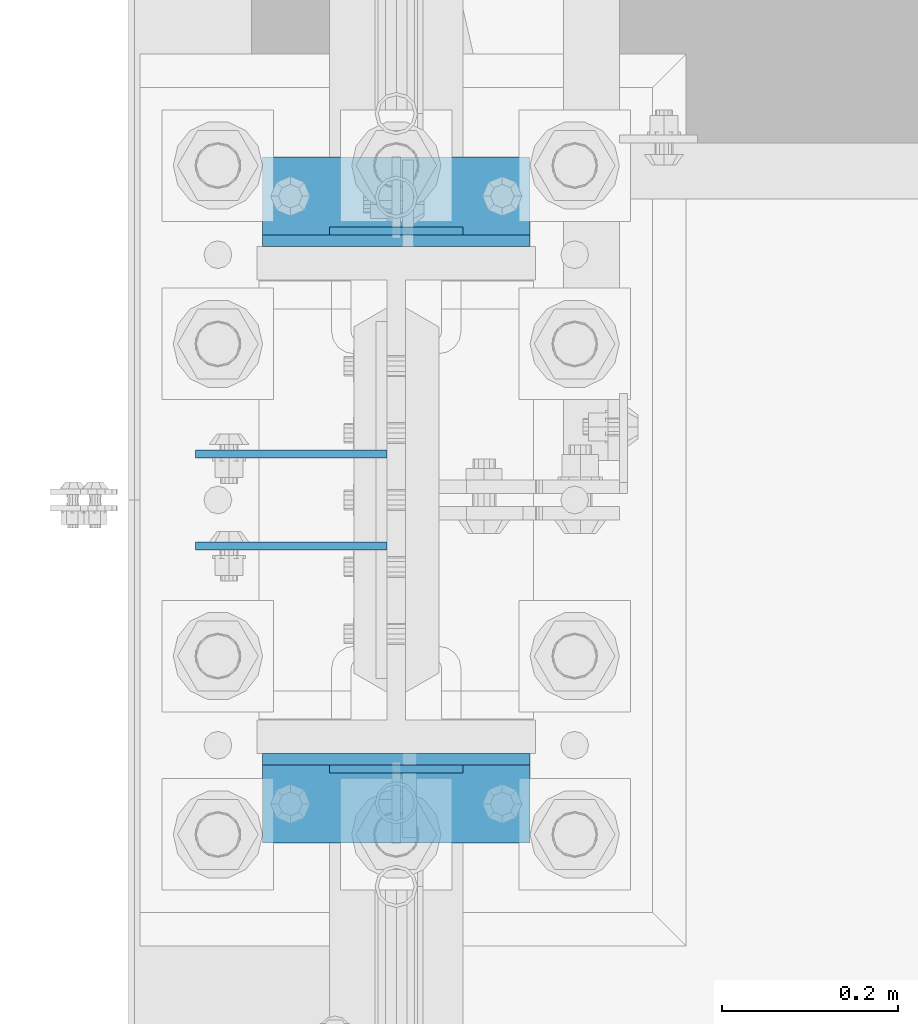
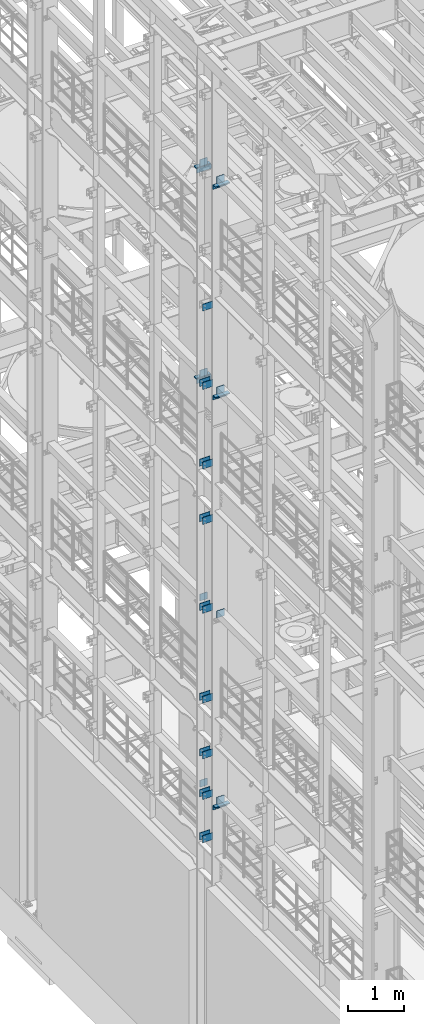
# One storey, part 1236 of 1876: 35 beams, 10 elements without a shape of their own.
"""IFC2X3 building model written with IfcOpenShell, lengths in millimetres."""

import ifcopenshell
import ifcopenshell.guid

model = None  # the IFC model being written
_history = None  # IfcOwnerHistory: only IFC2X3 demands one
_inside = {}  # id of a spatial element -> (the spatial element, [elements in it])
_under = {}  # id of a project, library or spatial element -> (it, [spatial elements below it])
_declared = {}  # id of a project -> (the project, [libraries it declares])
_typed = {}  # id of a type object -> (the type object, [elements of that type])
_made_of = {}  # id of a material, layer set ... -> (it, [elements and type objects made of it])


def new_model(schema):
    """Start an empty IFC model of exactly this schema.

    Asked for "IFC4X3", IfcOpenShell would pick the latest addendum, in which some entities
    have other attributes; the version numbers below select the first issue.
    IFC2X3 requires an IfcOwnerHistory on every rooted entity: one is made here for all.
    """
    global model, _history
    if schema == "IFC4X3":
        model = ifcopenshell.file(schema_version=(4, 3, 0, 0))
    else:
        model = ifcopenshell.file(schema=schema)
    _inside.clear()
    _under.clear()
    _declared.clear()
    _typed.clear()
    _made_of.clear()
    _history = None
    if model.schema == "IFC2X3":
        org = make("IfcOrganization", Name="unknown")
        user = make(
            "IfcPersonAndOrganization",
            ThePerson=make("IfcPerson", FamilyName="unknown"),
            TheOrganization=org,
        )
        app = make(
            "IfcApplication",
            ApplicationDeveloper=org,
            Version="unknown",
            ApplicationFullName="unknown",
            ApplicationIdentifier="unknown",
        )
        _history = make(
            "IfcOwnerHistory",
            OwningUser=user,
            OwningApplication=app,
            ChangeAction="ADDED",
            CreationDate=0,
        )
    return model


def make(cls, **values):
    """One entity of the class cls with the attributes given. An attribute that is None is left unset."""
    return model.create_entity(
        cls, **{name: value for name, value in values.items() if value is not None}
    )


def rooted(cls, **values):
    """An entity with a GlobalId (a new one), such as an element, a storey or a relation."""
    return make(cls, GlobalId=ifcopenshell.guid.new(), OwnerHistory=_history, **values)


def si_unit(unit_type, name, prefix=None):
    """IfcSIUnit, for example si_unit("LENGTHUNIT", "METRE", prefix="MILLI")."""
    return make("IfcSIUnit", UnitType=unit_type, Prefix=prefix, Name=name)


def assignment(units):
    """IfcUnitAssignment: the units of a project."""
    return None if units is None else make("IfcUnitAssignment", Units=units)


def point(xyz):
    """IfcCartesianPoint."""
    return None if xyz is None else make("IfcCartesianPoint", Coordinates=xyz)


def direction(xyz):
    """IfcDirection."""
    return None if xyz is None else make("IfcDirection", DirectionRatios=xyz)


def frame(location, z_axis=None, x_axis=None):
    """IfcAxis2Placement3D, a coordinate frame: its origin and axes. An axis left out is left unset."""
    return make(
        "IfcAxis2Placement3D",
        Location=point(location),
        Axis=direction(z_axis),
        RefDirection=direction(x_axis),
    )


def origin_with_axes():
    """The frame at (0, 0, 0) with the z axis (0, 0, 1) and the x axis (1, 0, 0) written out."""
    return frame((0.0, 0.0, 0.0), z_axis=(0.0, 0.0, 1.0), x_axis=(1.0, 0.0, 0.0))


def place(relative_to, where):
    """IfcLocalPlacement: puts the frame where relative to a parent placement (None: the world)."""
    return make(
        "IfcLocalPlacement", PlacementRelTo=relative_to, RelativePlacement=where
    )


def context(
    kind, dimensions, precision=None, world=None, true_north=None, identifier=None
):
    """IfcGeometricRepresentationContext, for example the 3D "Model" context."""
    return make(
        "IfcGeometricRepresentationContext",
        ContextIdentifier=identifier,
        ContextType=kind,
        CoordinateSpaceDimension=dimensions,
        Precision=precision,
        WorldCoordinateSystem=world,
        TrueNorth=true_north,
    )


def subcontext(parent, identifier, kind, view, scale=None):
    """IfcGeometricRepresentationSubContext, for example "Body" below "Model"."""
    return make(
        "IfcGeometricRepresentationSubContext",
        ContextIdentifier=identifier,
        ContextType=kind,
        ParentContext=parent,
        TargetScale=scale,
        TargetView=view,
    )


def project(units=None, contexts=None):
    """IfcProject with its units and contexts."""
    return rooted(
        "IfcProject",
        Name="project",
        RepresentationContexts=contexts,
        UnitsInContext=assignment(units),
    )


def spatial(cls, under=None, at=None, **own):
    """A site, building, storey or space (cls), placed at a placement, below another one or the project."""
    s = rooted(cls, ObjectPlacement=at, **own)
    if under is not None:
        _under.setdefault(under.id(), (under, []))[1].append(s)
    return s


def faces_of(points, faces, orient=None, outer=None):
    """IfcFace entities. A face is a list of loops; a loop is a list of indices into points, from 0.

    orient and outer hold one flag for each loop. By default every Orientation is true, the
    first loop of a face is its IfcFaceOuterBound and the others are IfcFaceBound.
    """
    made = []
    for i, loops in enumerate(faces):
        bounds = []
        for j, loop in enumerate(loops):
            is_outer = j == 0 if outer is None else outer[i][j]
            bounds.append(
                make(
                    "IfcFaceOuterBound" if is_outer else "IfcFaceBound",
                    Bound=make("IfcPolyLoop", Polygon=[points[k] for k in loop]),
                    Orientation=True if orient is None else orient[i][j],
                )
            )
        made.append(make("IfcFace", Bounds=bounds))
    return made


def faceted_brep(points, faces, orient=None, outer=None, voids=None):
    """IfcFacetedBrep: a solid bounded by flat faces; with voids (closed shells), ...WithVoids."""
    shared = [point(p) for p in points]
    hull = make("IfcClosedShell", CfsFaces=faces_of(shared, faces, orient, outer))
    if voids is None:
        return make("IfcFacetedBrep", Outer=hull)
    return make(
        "IfcFacetedBrepWithVoids",
        Outer=hull,
        Voids=[
            make(cls, CfsFaces=faces_of(shared, fs, o, b)) for cls, fs, o, b in voids
        ],
    )


def shape(context_of_items, identifier, shape_type, items):
    """IfcShapeRepresentation: the items that make up one representation, for example the "Body"."""
    return make(
        "IfcShapeRepresentation",
        ContextOfItems=context_of_items,
        RepresentationIdentifier=identifier,
        RepresentationType=shape_type,
        Items=items,
    )


def material(Name=None, Category=None):
    """IfcMaterial."""
    return make("IfcMaterial", Name=Name, Category=Category)


def made_of(thing, what):
    """Note that an element or type object is made of a material, layer set ...; save() writes the relation."""
    if what is not None:
        _made_of.setdefault(what.id(), (what, []))[1].append(thing)
    return thing


def type_object(cls, material=None, **own):
    """A type object (cls), such as IfcWallType, which elements share."""
    return made_of(rooted(cls, **own), material)


def element(
    cls,
    number,
    at=None,
    inside=None,
    cuts=None,
    type_object=None,
    material=None,
    context=None,
    identifier="Body",
    shape_type=None,
    held_by="IfcProductDefinitionShape",
    body=None,
    shapes=None,
    **own,
):
    """One element of the class cls, such as IfcWall. Its Tag is "e" and its number.

    at: its placement. inside: the storey or other place that contains it. cuts: it is an
    opening in that element (IfcRelVoidsElement). A single representation is given by context,
    identifier, shape_type and body (its items); several are given by shapes. held_by: the class
    of the entity that holds the representations. save() writes the other relations.
    """
    e = rooted(cls, Tag="e%d" % number, ObjectPlacement=at, **own)
    if body is not None:
        shapes = [shape(context, identifier, shape_type, body)]
    if shapes is not None:
        e.Representation = make(held_by, Representations=shapes)
    if inside is not None:
        _inside.setdefault(inside.id(), (inside, []))[1].append(e)
    if cuts is not None:
        rooted(
            "IfcRelVoidsElement", RelatingBuildingElement=cuts, RelatedOpeningElement=e
        )
    if type_object is not None:
        _typed.setdefault(type_object.id(), (type_object, []))[1].append(e)
    return made_of(e, material)


def aggregate(whole, parts):
    """IfcRelAggregates: a whole, such as a stair, and the parts it consists of."""
    return rooted("IfcRelAggregates", RelatingObject=whole, RelatedObjects=parts)


def save(model, path):
    """Write the relations noted so far, then the file.

    IfcRelAggregates (storeys below a building ...), IfcRelContainedInSpatialStructure (elements
    in a storey), IfcRelDefinesByType, IfcRelAssociatesMaterial and IfcRelDeclares: one each for
    every whole, place, type object, material and project.
    """
    for whole, parts in _under.values():
        aggregate(whole, parts)
    for where, things in _inside.values():
        rooted(
            "IfcRelContainedInSpatialStructure",
            RelatedElements=things,
            RelatingStructure=where,
        )
    for kind, things in _typed.values():
        rooted("IfcRelDefinesByType", RelatedObjects=things, RelatingType=kind)
    for what, things in _made_of.values():
        rooted("IfcRelAssociatesMaterial", RelatedObjects=things, RelatingMaterial=what)
    for by, libraries in _declared.values():
        rooted("IfcRelDeclares", RelatingContext=by, RelatedDefinitions=libraries)
    model.write(path)


model = new_model("IFC2X3")

# Units and contexts
model_context = context("Model", 3, precision=1e-05, world=origin_with_axes())
body_context = subcontext(model_context, "Body", "Model", "MODEL_VIEW")
ifc_project = project(units=[si_unit("LENGTHUNIT", "METRE", prefix="MILLI"), si_unit("AREAUNIT", "SQUARE_METRE"), si_unit("VOLUMEUNIT", "CUBIC_METRE"), si_unit("MASSUNIT", "GRAM", prefix="KILO"), si_unit("TIMEUNIT", "SECOND"), si_unit("PLANEANGLEUNIT", "RADIAN"), si_unit("SOLIDANGLEUNIT", "STERADIAN"), si_unit("THERMODYNAMICTEMPERATUREUNIT", "DEGREE_CELSIUS"), si_unit("LUMINOUSINTENSITYUNIT", "LUMEN")], contexts=[model_context])

# Site, building, storey
site_placement = place(None, origin_with_axes())
site = spatial("IfcSite", under=ifc_project, at=site_placement, CompositionType="ELEMENT")
building_placement = place(site_placement, origin_with_axes())
building = spatial("IfcBuilding", under=site, at=building_placement, Name="Undefined", CompositionType="ELEMENT")
storey_placement = place(building_placement, origin_with_axes())
storey = spatial("IfcBuildingStorey", under=building, at=storey_placement, Name="Undefined", CompositionType="ELEMENT", Elevation=0.0)

# Assembly, beams
assembly_1_placement = place(storey_placement, origin_with_axes())
assembly_1 = element("IfcElementAssembly", 1, at=assembly_1_placement, inside=storey, Name="COLUMN", AssemblyPlace="NOTDEFINED", PredefinedType="RIGID_FRAME")
ifc_material = material(Name="STEEL/A36")
beam_type_1 = type_object("IfcBeamType", PredefinedType="NOTDEFINED")
beam_1_placement = place(assembly_1_placement, frame((-10.31875, 1471.61250152589, 17056.1), z_axis=(0.0, 0.0, -1.0), x_axis=(-1.0, 0.0, 0.0)))
beam_1 = element("IfcBeam", 2, at=beam_1_placement, type_object=beam_type_1, material=ifc_material, Name="PLATE", context=body_context, shape_type="Brep", body=[
    faceted_brep([(0.0, 4.76249999999982, -76.1999999999998), (3.63797880709171e-12, 4.76249999999982, 76.1999969482422), (218.28125, 4.76250000000005, 76.2000000000007), (218.28125, 4.76250000000005, -76.2000000000007), (3.63797880709171e-12, -4.76249999999982, 76.1999969482422), (218.28125, -4.76250000000005, 76.2000000000007), (0.0, -4.76249999999982, -76.1999999999998), (218.28125, -4.76250000000005, -76.2000000000007)], [[[0, 1, 2, 3]], [[1, 4, 5, 2]], [[4, 6, 7, 5]], [[6, 0, 3, 7]], [[5, 7, 3, 2]], [[6, 4, 1, 0]]]),
])
beam_2_placement = place(assembly_1_placement, frame((-10.31875, 1576.38750152589, 15335.25), z_axis=(0.0, 0.0, -1.0), x_axis=(-1.0, 0.0, 0.0)))
beam_2 = element("IfcBeam", 3, at=beam_2_placement, type_object=beam_type_1, material=ifc_material, Name="PLATE", context=body_context, shape_type="Brep", body=[
    faceted_brep([(0.0, 4.76249999999982, -76.1999999999998), (3.63797880709171e-12, 4.76249999999982, 76.1999969482422), (218.28125, 4.76250000000005, 76.2000000000007), (218.28125, 4.76250000000005, -76.2000000000007), (3.63797880709171e-12, -4.76249999999982, 76.1999969482422), (218.28125, -4.76250000000005, 76.2000000000007), (0.0, -4.76249999999982, -76.1999999999998), (218.28125, -4.76250000000005, -76.2000000000007)], [[[0, 1, 2, 3]], [[1, 4, 5, 2]], [[4, 6, 7, 5]], [[6, 0, 3, 7]], [[5, 7, 3, 2]], [[6, 4, 1, 0]]]),
])
beam_3_placement = place(assembly_1_placement, frame((-10.31875, 1471.61250152589, 15335.25), z_axis=(0.0, 0.0, -1.0), x_axis=(-1.0, 0.0, 0.0)))
beam_3 = element("IfcBeam", 4, at=beam_3_placement, type_object=beam_type_1, material=ifc_material, Name="PLATE", context=body_context, shape_type="Brep", body=[
    faceted_brep([(0.0, 4.76249999999982, -76.1999999999998), (3.63797880709171e-12, 4.76249999999982, 76.1999969482422), (218.28125, 4.76250000000005, 76.2000000000007), (218.28125, 4.76250000000005, -76.2000000000007), (3.63797880709171e-12, -4.76249999999982, 76.1999969482422), (218.28125, -4.76250000000005, 76.2000000000007), (0.0, -4.76249999999982, -76.1999999999998), (218.28125, -4.76250000000005, -76.2000000000007)], [[[0, 1, 2, 3]], [[1, 4, 5, 2]], [[4, 6, 7, 5]], [[6, 0, 3, 7]], [[5, 7, 3, 2]], [[6, 4, 1, 0]]]),
])

assembly_2_placement = place(storey_placement, origin_with_axes())
assembly_2 = element("IfcElementAssembly", 5, at=assembly_2_placement, inside=storey, Name="COLUMN", AssemblyPlace="NOTDEFINED", PredefinedType="RIGID_FRAME")
beam_4_placement = place(assembly_2_placement, frame((-10.31875, 1576.38750152589, 13589.0), z_axis=(0.0, 0.0, -1.0), x_axis=(-1.0, 0.0, 0.0)))
beam_4 = element("IfcBeam", 6, at=beam_4_placement, type_object=beam_type_1, material=ifc_material, Name="PLATE", context=body_context, shape_type="Brep", body=[
    faceted_brep([(0.0, 4.76249999999982, -76.1999999999998), (3.63797880709171e-12, 4.76249999999982, 76.1999969482422), (218.28125, 4.76250000000005, 76.2000000000007), (218.28125, 4.76250000000005, -76.2000000000007), (3.63797880709171e-12, -4.76249999999982, 76.1999969482422), (218.28125, -4.76250000000005, 76.2000000000007), (0.0, -4.76249999999982, -76.1999999999998), (218.28125, -4.76250000000005, -76.2000000000007)], [[[0, 1, 2, 3]], [[1, 4, 5, 2]], [[4, 6, 7, 5]], [[6, 0, 3, 7]], [[5, 7, 3, 2]], [[6, 4, 1, 0]]]),
])
beam_5_placement = place(assembly_2_placement, frame((-10.31875, 1471.61250152589, 13589.0), z_axis=(0.0, 0.0, -1.0), x_axis=(-1.0, 0.0, 0.0)))
beam_5 = element("IfcBeam", 7, at=beam_5_placement, type_object=beam_type_1, material=ifc_material, Name="PLATE", context=body_context, shape_type="Brep", body=[
    faceted_brep([(0.0, 4.76249999999982, -76.1999999999998), (3.63797880709171e-12, 4.76249999999982, 76.1999969482422), (218.28125, 4.76250000000005, 76.2000000000007), (218.28125, 4.76250000000005, -76.2000000000007), (3.63797880709171e-12, -4.76249999999982, 76.1999969482422), (218.28125, -4.76250000000005, 76.2000000000007), (0.0, -4.76249999999982, -76.1999999999998), (218.28125, -4.76250000000005, -76.2000000000007)], [[[0, 1, 2, 3]], [[1, 4, 5, 2]], [[4, 6, 7, 5]], [[6, 0, 3, 7]], [[5, 7, 3, 2]], [[6, 4, 1, 0]]]),
])
beam_6_placement = place(assembly_2_placement, frame((-10.31875, 1576.38750152589, 12369.8), z_axis=(0.0, 0.0, -1.0), x_axis=(-1.0, 0.0, 0.0)))
beam_6 = element("IfcBeam", 8, at=beam_6_placement, type_object=beam_type_1, material=ifc_material, Name="PLATE", context=body_context, shape_type="Brep", body=[
    faceted_brep([(0.0, 4.76249999999982, -76.1999999999998), (3.63797880709171e-12, 4.76249999999982, 76.1999969482422), (218.28125, 4.76250000000005, 76.2000000000007), (218.28125, 4.76250000000005, -76.2000000000007), (3.63797880709171e-12, -4.76249999999982, 76.1999969482422), (218.28125, -4.76250000000005, 76.2000000000007), (0.0, -4.76249999999982, -76.1999999999998), (218.28125, -4.76250000000005, -76.2000000000007)], [[[0, 1, 2, 3]], [[1, 4, 5, 2]], [[4, 6, 7, 5]], [[6, 0, 3, 7]], [[5, 7, 3, 2]], [[6, 4, 1, 0]]]),
])
beam_7_placement = place(assembly_2_placement, frame((-10.31875, 1471.61250152589, 12369.8), z_axis=(0.0, 0.0, -1.0), x_axis=(-1.0, 0.0, 0.0)))
beam_7 = element("IfcBeam", 9, at=beam_7_placement, type_object=beam_type_1, material=ifc_material, Name="PLATE", context=body_context, shape_type="Brep", body=[
    faceted_brep([(0.0, 4.76249999999982, -76.1999999999998), (3.63797880709171e-12, 4.76249999999982, 76.1999969482422), (218.28125, 4.76250000000005, 76.2000000000007), (218.28125, 4.76250000000005, -76.2000000000007), (3.63797880709171e-12, -4.76249999999982, 76.1999969482422), (218.28125, -4.76250000000005, 76.2000000000007), (0.0, -4.76249999999982, -76.1999999999998), (218.28125, -4.76250000000005, -76.2000000000007)], [[[0, 1, 2, 3]], [[1, 4, 5, 2]], [[4, 6, 7, 5]], [[6, 0, 3, 7]], [[5, 7, 3, 2]], [[6, 4, 1, 0]]]),
])
beam_8_placement = place(assembly_2_placement, frame((-10.31875, 1576.38750152589, 10420.35), z_axis=(0.0, 0.0, -1.0), x_axis=(-1.0, 0.0, 0.0)))
beam_8 = element("IfcBeam", 10, at=beam_8_placement, type_object=beam_type_1, material=ifc_material, Name="PLATE", context=body_context, shape_type="Brep", body=[
    faceted_brep([(0.0, 4.76249999999982, -76.1999999999998), (3.63797880709171e-12, 4.76249999999982, 76.1999969482422), (218.28125, 4.76250000000005, 76.2000000000007), (218.28125, 4.76250000000005, -76.2000000000007), (3.63797880709171e-12, -4.76249999999982, 76.1999969482422), (218.28125, -4.76250000000005, 76.2000000000007), (0.0, -4.76249999999982, -76.1999999999998), (218.28125, -4.76250000000005, -76.2000000000007)], [[[0, 1, 2, 3]], [[1, 4, 5, 2]], [[4, 6, 7, 5]], [[6, 0, 3, 7]], [[5, 7, 3, 2]], [[6, 4, 1, 0]]]),
])
beam_9_placement = place(assembly_2_placement, frame((-10.31875, 1471.61250152589, 10420.35), z_axis=(0.0, 0.0, -1.0), x_axis=(-1.0, 0.0, 0.0)))
beam_9 = element("IfcBeam", 11, at=beam_9_placement, type_object=beam_type_1, material=ifc_material, Name="PLATE", context=body_context, shape_type="Brep", body=[
    faceted_brep([(0.0, 4.76249999999982, -76.1999999999998), (3.63797880709171e-12, 4.76249999999982, 76.1999969482422), (218.28125, 4.76250000000005, 76.2000000000007), (218.28125, 4.76250000000005, -76.2000000000007), (3.63797880709171e-12, -4.76249999999982, 76.1999969482422), (218.28125, -4.76250000000005, 76.2000000000007), (0.0, -4.76249999999982, -76.1999999999998), (218.28125, -4.76250000000005, -76.2000000000007)], [[[0, 1, 2, 3]], [[1, 4, 5, 2]], [[4, 6, 7, 5]], [[6, 0, 3, 7]], [[5, 7, 3, 2]], [[6, 4, 1, 0]]]),
])
beam_10_placement = place(assembly_2_placement, frame((-10.31875, 1576.38750152589, 8445.5), z_axis=(0.0, 0.0, -1.0), x_axis=(-1.0, 0.0, 0.0)))
beam_10 = element("IfcBeam", 12, at=beam_10_placement, type_object=beam_type_1, material=ifc_material, Name="PLATE", context=body_context, shape_type="Brep", body=[
    faceted_brep([(0.0, 4.76249999999982, -76.1999999999998), (3.63797880709171e-12, 4.76249999999982, 76.1999969482422), (218.28125, 4.76250000000005, 76.2000000000007), (218.28125, 4.76250000000005, -76.2000000000007), (3.63797880709171e-12, -4.76249999999982, 76.1999969482422), (218.28125, -4.76250000000005, 76.2000000000007), (0.0, -4.76249999999982, -76.1999999999998), (218.28125, -4.76250000000005, -76.2000000000007)], [[[0, 1, 2, 3]], [[1, 4, 5, 2]], [[4, 6, 7, 5]], [[6, 0, 3, 7]], [[5, 7, 3, 2]], [[6, 4, 1, 0]]]),
])
beam_11_placement = place(assembly_2_placement, frame((-10.31875, 1471.61250152589, 8445.5), z_axis=(0.0, 0.0, -1.0), x_axis=(-1.0, 0.0, 0.0)))
beam_11 = element("IfcBeam", 13, at=beam_11_placement, type_object=beam_type_1, material=ifc_material, Name="PLATE", context=body_context, shape_type="Brep", body=[
    faceted_brep([(0.0, 4.76249999999982, -76.1999999999998), (3.63797880709171e-12, 4.76249999999982, 76.1999969482422), (218.28125, 4.76250000000005, 76.2000000000007), (218.28125, 4.76250000000005, -76.2000000000007), (3.63797880709171e-12, -4.76249999999982, 76.1999969482422), (218.28125, -4.76250000000005, 76.2000000000007), (0.0, -4.76249999999982, -76.1999999999998), (218.28125, -4.76250000000005, -76.2000000000007)], [[[0, 1, 2, 3]], [[1, 4, 5, 2]], [[4, 6, 7, 5]], [[6, 0, 3, 7]], [[5, 7, 3, 2]], [[6, 4, 1, 0]]]),
])
beam_12_placement = place(assembly_2_placement, frame((-10.31875, 1576.38750152589, 7226.3), z_axis=(0.0, 0.0, -1.0), x_axis=(-1.0, 0.0, 0.0)))
beam_12 = element("IfcBeam", 14, at=beam_12_placement, type_object=beam_type_1, material=ifc_material, Name="PLATE", context=body_context, shape_type="Brep", body=[
    faceted_brep([(0.0, 4.76249999999982, -76.1999999999998), (3.63797880709171e-12, 4.76249999999982, 76.1999969482422), (218.28125, 4.76250000000005, 76.2000000000007), (218.28125, 4.76250000000005, -76.2000000000007), (3.63797880709171e-12, -4.76249999999982, 76.1999969482422), (218.28125, -4.76250000000005, 76.2000000000007), (0.0, -4.76249999999982, -76.1999999999998), (218.28125, -4.76250000000005, -76.2000000000007)], [[[0, 1, 2, 3]], [[1, 4, 5, 2]], [[4, 6, 7, 5]], [[6, 0, 3, 7]], [[5, 7, 3, 2]], [[6, 4, 1, 0]]]),
])
beam_13_placement = place(assembly_2_placement, frame((-10.31875, 1471.61250152589, 7226.3), z_axis=(0.0, 0.0, -1.0), x_axis=(-1.0, 0.0, 0.0)))
beam_13 = element("IfcBeam", 15, at=beam_13_placement, type_object=beam_type_1, material=ifc_material, Name="PLATE", context=body_context, shape_type="Brep", body=[
    faceted_brep([(0.0, 4.76249999999982, -76.1999999999998), (3.63797880709171e-12, 4.76249999999982, 76.1999969482422), (218.28125, 4.76250000000005, 76.2000000000007), (218.28125, 4.76250000000005, -76.2000000000007), (3.63797880709171e-12, -4.76249999999982, 76.1999969482422), (218.28125, -4.76250000000005, 76.2000000000007), (0.0, -4.76249999999982, -76.1999999999998), (218.28125, -4.76250000000005, -76.2000000000007)], [[[0, 1, 2, 3]], [[1, 4, 5, 2]], [[4, 6, 7, 5]], [[6, 0, 3, 7]], [[5, 7, 3, 2]], [[6, 4, 1, 0]]]),
])
beam_14_placement = place(assembly_2_placement, frame((-10.31875, 1576.38750152589, 5384.8), z_axis=(0.0, 0.0, -1.0), x_axis=(-1.0, 0.0, 0.0)))
beam_14 = element("IfcBeam", 16, at=beam_14_placement, type_object=beam_type_1, material=ifc_material, Name="PLATE", context=body_context, shape_type="Brep", body=[
    faceted_brep([(0.0, 4.76249999999982, -76.1999999999998), (3.63797880709171e-12, 4.76249999999982, 76.1999969482422), (218.28125, 4.76250000000005, 76.2000000000007), (218.28125, 4.76250000000005, -76.2000000000007), (3.63797880709171e-12, -4.76249999999982, 76.1999969482422), (218.28125, -4.76250000000005, 76.2000000000007), (0.0, -4.76249999999982, -76.1999999999998), (218.28125, -4.76250000000005, -76.2000000000007)], [[[0, 1, 2, 3]], [[1, 4, 5, 2]], [[4, 6, 7, 5]], [[6, 0, 3, 7]], [[5, 7, 3, 2]], [[6, 4, 1, 0]]]),
])
beam_15_placement = place(assembly_2_placement, frame((-10.31875, 1471.61250152589, 5384.8), z_axis=(0.0, 0.0, -1.0), x_axis=(-1.0, 0.0, 0.0)))
beam_15 = element("IfcBeam", 17, at=beam_15_placement, type_object=beam_type_1, material=ifc_material, Name="PLATE", context=body_context, shape_type="Brep", body=[
    faceted_brep([(0.0, 4.76249999999982, -76.1999999999998), (3.63797880709171e-12, 4.76249999999982, 76.1999969482422), (218.28125, 4.76250000000005, 76.2000000000007), (218.28125, 4.76250000000005, -76.2000000000007), (3.63797880709171e-12, -4.76249999999982, 76.1999969482422), (218.28125, -4.76250000000005, 76.2000000000007), (0.0, -4.76249999999982, -76.1999999999998), (218.28125, -4.76250000000005, -76.2000000000007)], [[[0, 1, 2, 3]], [[1, 4, 5, 2]], [[4, 6, 7, 5]], [[6, 0, 3, 7]], [[5, 7, 3, 2]], [[6, 4, 1, 0]]]),
])
beam_16_placement = place(assembly_2_placement, frame((-10.31875, 1576.38750152589, 6330.95), z_axis=(0.0, 0.0, -1.0), x_axis=(-1.0, 0.0, 0.0)))
beam_16 = element("IfcBeam", 18, at=beam_16_placement, type_object=beam_type_1, material=ifc_material, Name="PLATE", context=body_context, shape_type="Brep", body=[
    faceted_brep([(0.0, 4.76249999999982, -76.1999999999998), (3.63797880709171e-12, 4.76249999999982, 76.1999969482422), (218.28125, 4.76250000000005, 76.2000000000007), (218.28125, 4.76250000000005, -76.2000000000007), (3.63797880709171e-12, -4.76249999999982, 76.1999969482422), (218.28125, -4.76250000000005, 76.2000000000007), (0.0, -4.76249999999982, -76.1999999999998), (218.28125, -4.76250000000005, -76.2000000000007)], [[[0, 1, 2, 3]], [[1, 4, 5, 2]], [[4, 6, 7, 5]], [[6, 0, 3, 7]], [[5, 7, 3, 2]], [[6, 4, 1, 0]]]),
])
beam_17_placement = place(assembly_2_placement, frame((-10.31875, 1471.61250152589, 6330.95), z_axis=(0.0, 0.0, -1.0), x_axis=(-1.0, 0.0, 0.0)))
beam_17 = element("IfcBeam", 19, at=beam_17_placement, type_object=beam_type_1, material=ifc_material, Name="PLATE", context=body_context, shape_type="Brep", body=[
    faceted_brep([(0.0, 4.76249999999982, -76.1999999999998), (3.63797880709171e-12, 4.76249999999982, 76.1999969482422), (218.28125, 4.76250000000005, 76.2000000000007), (218.28125, 4.76250000000005, -76.2000000000007), (3.63797880709171e-12, -4.76249999999982, 76.1999969482422), (218.28125, -4.76250000000005, 76.2000000000007), (0.0, -4.76249999999982, -76.1999999999998), (218.28125, -4.76250000000005, -76.2000000000007)], [[[0, 1, 2, 3]], [[1, 4, 5, 2]], [[4, 6, 7, 5]], [[6, 0, 3, 7]], [[5, 7, 3, 2]], [[6, 4, 1, 0]]]),
])

# Assembly, beam
assembly_3_placement = place(storey_placement, origin_with_axes())
assembly_3 = element("IfcElementAssembly", 20, at=assembly_3_placement, inside=storey, Name="BEAM", AssemblyPlace="NOTDEFINED", PredefinedType="RIGID_FRAME")
beam_18_placement = place(assembly_3_placement, frame((76.1999999999998, 1830.3875, 19958.05), z_axis=(0.0, 0.0, 1.0), x_axis=(-1.0, 0.0, 0.0)))
beam_18 = element("IfcBeam", 21, at=beam_18_placement, type_object=beam_type_1, material=ifc_material, Name="PLATE", context=body_context, shape_type="Brep", body=[
    faceted_brep([(0.0, 4.76249999999982, -76.1999999999998), (3.63797880709171e-12, 4.76249999999982, 76.1999969482422), (152.399993896484, 4.76250000000073, 76.1999969482422), (152.4, 4.76249999999982, -76.1999999999998), (3.63797880709171e-12, -4.76249999999982, 76.1999969482422), (152.399993896484, -4.76250000000073, 76.1999969482422), (0.0, -4.76249999999982, -76.1999999999998), (152.4, -4.76249999999982, -76.1999999999998)], [[[0, 1, 2, 3]], [[4, 5, 2, 1]], [[4, 6, 7, 5]], [[6, 0, 3, 7]], [[5, 7, 3, 2]], [[6, 4, 1, 0]]]),
])

assembly_4_placement = place(storey_placement, origin_with_axes())
assembly_4 = element("IfcElementAssembly", 22, at=assembly_4_placement, inside=storey, Name="BEAM", AssemblyPlace="NOTDEFINED", PredefinedType="RIGID_FRAME")
beam_19_placement = place(assembly_4_placement, frame((76.1999999999998, 1217.6125, 19958.05), z_axis=(0.0, 0.0, -1.0), x_axis=(-1.0, 0.0, 0.0)))
beam_19 = element("IfcBeam", 23, at=beam_19_placement, type_object=beam_type_1, material=ifc_material, Name="PLATE", context=body_context, shape_type="Brep", body=[
    faceted_brep([(0.0, 4.76249999999982, -76.1999999999998), (3.63797880709171e-12, 4.76249999999982, 76.1999969482422), (152.399993896484, 4.76250000000073, 76.1999969482422), (152.4, 4.76249999999982, -76.1999999999998), (3.63797880709171e-12, -4.76249999999982, 76.1999969482422), (152.399993896484, -4.76250000000073, 76.1999969482422), (0.0, -4.76249999999982, -76.1999999999998), (152.4, -4.76249999999982, -76.1999999999998)], [[[0, 1, 2, 3]], [[4, 5, 2, 1]], [[4, 6, 7, 5]], [[6, 0, 3, 7]], [[5, 7, 3, 2]], [[6, 4, 1, 0]]]),
])

assembly_5_placement = place(storey_placement, origin_with_axes())
assembly_5 = element("IfcElementAssembly", 24, at=assembly_5_placement, inside=storey, Name="BEAM", AssemblyPlace="NOTDEFINED", PredefinedType="RIGID_FRAME")
beam_20_placement = place(assembly_5_placement, frame((76.1999999999998, 1830.3875, 15335.25), z_axis=(0.0, 0.0, 1.0), x_axis=(-1.0, 0.0, 0.0)))
beam_20 = element("IfcBeam", 25, at=beam_20_placement, type_object=beam_type_1, material=ifc_material, Name="PLATE", context=body_context, shape_type="Brep", body=[
    faceted_brep([(0.0, 4.76249999999982, -76.1999999999998), (3.63797880709171e-12, 4.76249999999982, 76.1999969482422), (152.399993896484, 4.76250000000073, 76.1999969482422), (152.4, 4.76249999999982, -76.1999999999998), (3.63797880709171e-12, -4.76249999999982, 76.1999969482422), (152.399993896484, -4.76250000000073, 76.1999969482422), (0.0, -4.76249999999982, -76.1999999999998), (152.4, -4.76249999999982, -76.1999999999998)], [[[0, 1, 2, 3]], [[4, 5, 2, 1]], [[4, 6, 7, 5]], [[6, 0, 3, 7]], [[5, 7, 3, 2]], [[6, 4, 1, 0]]]),
])

assembly_6_placement = place(storey_placement, origin_with_axes())
assembly_6 = element("IfcElementAssembly", 26, at=assembly_6_placement, inside=storey, Name="BEAM", AssemblyPlace="NOTDEFINED", PredefinedType="RIGID_FRAME")
beam_21_placement = place(assembly_6_placement, frame((76.1999999999998, 1217.6125, 15335.25), z_axis=(0.0, 0.0, -1.0), x_axis=(-1.0, 0.0, 0.0)))
beam_21 = element("IfcBeam", 27, at=beam_21_placement, type_object=beam_type_1, material=ifc_material, Name="PLATE", context=body_context, shape_type="Brep", body=[
    faceted_brep([(0.0, 4.76249999999982, -76.1999999999998), (3.63797880709171e-12, 4.76249999999982, 76.1999969482422), (152.399993896484, 4.76250000000073, 76.1999969482422), (152.4, 4.76249999999982, -76.1999999999998), (3.63797880709171e-12, -4.76249999999982, 76.1999969482422), (152.399993896484, -4.76250000000073, 76.1999969482422), (0.0, -4.76249999999982, -76.1999999999998), (152.4, -4.76249999999982, -76.1999999999998)], [[[0, 1, 2, 3]], [[4, 5, 2, 1]], [[4, 6, 7, 5]], [[6, 0, 3, 7]], [[5, 7, 3, 2]], [[6, 4, 1, 0]]]),
])

assembly_7_placement = place(storey_placement, origin_with_axes())
assembly_7 = element("IfcElementAssembly", 28, at=assembly_7_placement, inside=storey, Name="BEAM", AssemblyPlace="NOTDEFINED", PredefinedType="RIGID_FRAME")
beam_22_placement = place(assembly_7_placement, frame((76.1999999999998, 1830.3875, 10420.35), z_axis=(0.0, 0.0, 1.0), x_axis=(-1.0, 0.0, 0.0)))
beam_22 = element("IfcBeam", 29, at=beam_22_placement, type_object=beam_type_1, material=ifc_material, Name="PLATE", context=body_context, shape_type="Brep", body=[
    faceted_brep([(0.0, 4.76249999999982, -76.1999999999998), (3.63797880709171e-12, 4.76249999999982, 76.1999969482422), (152.399993896484, 4.76250000000073, 76.1999969482422), (152.4, 4.76249999999982, -76.1999999999998), (3.63797880709171e-12, -4.76249999999982, 76.1999969482422), (152.399993896484, -4.76250000000073, 76.1999969482422), (0.0, -4.76249999999982, -76.1999999999998), (152.4, -4.76249999999982, -76.1999999999998)], [[[0, 1, 2, 3]], [[4, 5, 2, 1]], [[4, 6, 7, 5]], [[6, 0, 3, 7]], [[5, 7, 3, 2]], [[6, 4, 1, 0]]]),
])
aggregate(assembly_7, [beam_22])

assembly_8_placement = place(storey_placement, origin_with_axes())
assembly_8 = element("IfcElementAssembly", 30, at=assembly_8_placement, inside=storey, Name="BEAM", AssemblyPlace="NOTDEFINED", PredefinedType="RIGID_FRAME")
beam_23_placement = place(assembly_8_placement, frame((76.1999999999998, 1217.6125, 10420.35), z_axis=(0.0, 0.0, -1.0), x_axis=(-1.0, 0.0, 0.0)))
beam_23 = element("IfcBeam", 31, at=beam_23_placement, type_object=beam_type_1, material=ifc_material, Name="PLATE", context=body_context, shape_type="Brep", body=[
    faceted_brep([(0.0, 4.76249999999982, -76.1999999999998), (3.63797880709171e-12, 4.76249999999982, 76.1999969482422), (152.399993896484, 4.76250000000073, 76.1999969482422), (152.4, 4.76249999999982, -76.1999999999998), (3.63797880709171e-12, -4.76249999999982, 76.1999969482422), (152.399993896484, -4.76250000000073, 76.1999969482422), (0.0, -4.76249999999982, -76.1999999999998), (152.4, -4.76249999999982, -76.1999999999998)], [[[0, 1, 2, 3]], [[4, 5, 2, 1]], [[4, 6, 7, 5]], [[6, 0, 3, 7]], [[5, 7, 3, 2]], [[6, 4, 1, 0]]]),
])
aggregate(assembly_8, [beam_23])

assembly_9_placement = place(storey_placement, origin_with_axes())
assembly_9 = element("IfcElementAssembly", 32, at=assembly_9_placement, inside=storey, Name="BEAM", AssemblyPlace="NOTDEFINED", PredefinedType="RIGID_FRAME")
beam_24_placement = place(assembly_9_placement, frame((76.1999999999998, 1830.3875, 6330.95), z_axis=(0.0, 0.0, 1.0), x_axis=(-1.0, 0.0, 0.0)))
beam_24 = element("IfcBeam", 33, at=beam_24_placement, type_object=beam_type_1, material=ifc_material, Name="PLATE", context=body_context, shape_type="Brep", body=[
    faceted_brep([(0.0, 4.76249999999982, -76.1999999999998), (3.63797880709171e-12, 4.76249999999982, 76.1999969482422), (152.399993896484, 4.76250000000073, 76.1999969482422), (152.4, 4.76249999999982, -76.1999999999998), (3.63797880709171e-12, -4.76249999999982, 76.1999969482422), (152.399993896484, -4.76250000000073, 76.1999969482422), (0.0, -4.76249999999982, -76.1999999999998), (152.4, -4.76249999999982, -76.1999999999998)], [[[0, 1, 2, 3]], [[4, 5, 2, 1]], [[4, 6, 7, 5]], [[6, 0, 3, 7]], [[5, 7, 3, 2]], [[6, 4, 1, 0]]]),
])
aggregate(assembly_9, [beam_24])

# Assembly, beams
assembly_10_placement = place(storey_placement, origin_with_axes())
assembly_10 = element("IfcElementAssembly", 34, at=assembly_10_placement, inside=storey, Name="BEAM", AssemblyPlace="NOTDEFINED", PredefinedType="RIGID_FRAME")
beam_25_placement = place(assembly_10_placement, frame((76.2, 1217.6125, 6330.95), z_axis=(0.0, 0.0, -1.0), x_axis=(-1.0, 0.0, 0.0)))
beam_25 = element("IfcBeam", 35, at=beam_25_placement, type_object=beam_type_1, material=ifc_material, Name="PLATE", context=body_context, shape_type="Brep", body=[
    faceted_brep([(0.0, 4.76249999999982, -76.1999999999998), (3.63797880709171e-12, 4.76249999999982, 76.1999969482422), (152.399993896484, 4.76250000000073, 76.1999969482422), (152.4, 4.76249999999982, -76.1999999999998), (3.63797880709171e-12, -4.76249999999982, 76.1999969482422), (152.399993896484, -4.76250000000073, 76.1999969482422), (0.0, -4.76249999999982, -76.1999999999998), (152.4, -4.76249999999982, -76.1999999999998)], [[[0, 1, 2, 3]], [[4, 5, 2, 1]], [[4, 6, 7, 5]], [[6, 0, 3, 7]], [[5, 7, 3, 2]], [[6, 4, 1, 0]]]),
])
beam_type_2 = type_object("IfcBeamType", PredefinedType="NOTDEFINED")
beam_26_placement = place(assembly_10_placement, frame((-152.400000000001, 1177.925, 6249.9875), z_axis=(0.0, -1.0, 0.0), x_axis=(1.0, 0.0, 0.0)))
beam_26 = element("IfcBeam", 36, at=beam_26_placement, type_object=beam_type_2, material=ifc_material, Name="PLATE", context=body_context, shape_type="Brep", body=[
    faceted_brep([(0.0, 4.76250000000073, -44.4499999999998), (0.0, 4.76250000000073, 44.4499999999998), (304.799999999999, 4.76250000000073, 44.4499999999998), (304.799999999999, 4.76250000000073, -44.4499999999998), (0.0, -4.76250000000073, 44.4499999999998), (304.799999999999, -4.76250000000073, 44.4499999999998), (0.0, -4.76250000000073, -44.4499999999998), (304.799999999999, -4.76250000000073, -44.4499999999998)], [[[0, 1, 2, 3]], [[1, 4, 5, 2]], [[4, 6, 7, 5]], [[6, 0, 3, 7]], [[5, 7, 3, 2]], [[6, 4, 1, 0]]]),
])
aggregate(assembly_10, [beam_25, beam_26])

# Beam
beam_27_placement = place(assembly_4_placement, frame((-152.400000000001, 1177.925, 19877.0875), z_axis=(0.0, -1.0, 0.0), x_axis=(1.0, 0.0, 0.0)))
beam_27 = element("IfcBeam", 37, at=beam_27_placement, type_object=beam_type_2, material=ifc_material, Name="PLATE", context=body_context, shape_type="Brep", body=[
    faceted_brep([(0.0, 4.76250000000073, -44.4499999999998), (0.0, 4.76250000000073, 44.4499999999998), (304.799999999999, 4.76250000000073, 44.4499999999998), (304.799999999999, 4.76250000000073, -44.4499999999998), (0.0, -4.76250000000073, 44.4499999999998), (304.799999999999, -4.76250000000073, 44.4499999999998), (0.0, -4.76250000000073, -44.4499999999998), (304.799999999999, -4.76250000000073, -44.4499999999998)], [[[0, 1, 2, 3]], [[1, 4, 5, 2]], [[4, 6, 7, 5]], [[6, 0, 3, 7]], [[5, 7, 3, 2]], [[6, 4, 1, 0]]]),
])

aggregate(assembly_4, [beam_19, beam_27])

beam_28_placement = place(assembly_3_placement, frame((-152.400000000001, 1870.075, 19877.0875), z_axis=(0.0, 1.0, 0.0), x_axis=(1.0, 0.0, 0.0)))
beam_28 = element("IfcBeam", 38, at=beam_28_placement, type_object=beam_type_2, material=ifc_material, Name="PLATE", context=body_context, shape_type="Brep", body=[
    faceted_brep([(0.0, 4.76250000000073, -44.4499999999998), (0.0, 4.76250000000073, 44.4499999999998), (304.799999999999, 4.76250000000073, 44.4499999999998), (304.799999999999, 4.76250000000073, -44.4499999999998), (0.0, -4.76250000000073, 44.4499999999998), (304.799999999999, -4.76250000000073, 44.4499999999998), (0.0, -4.76250000000073, -44.4499999999998), (304.799999999999, -4.76250000000073, -44.4499999999998)], [[[0, 1, 2, 3]], [[1, 4, 5, 2]], [[4, 6, 7, 5]], [[6, 0, 3, 7]], [[5, 7, 3, 2]], [[6, 4, 1, 0]]]),
])

aggregate(assembly_3, [beam_18, beam_28])

beam_29_placement = place(assembly_6_placement, frame((-152.400000000001, 1177.925, 15254.2875), z_axis=(0.0, -1.0, 0.0), x_axis=(1.0, 0.0, 0.0)))
beam_29 = element("IfcBeam", 39, at=beam_29_placement, type_object=beam_type_2, material=ifc_material, Name="PLATE", context=body_context, shape_type="Brep", body=[
    faceted_brep([(0.0, 4.76250000000073, -44.4499999999998), (0.0, 4.76250000000073, 44.4499999999998), (304.799999999999, 4.76250000000073, 44.4499999999998), (304.799999999999, 4.76250000000073, -44.4499999999998), (0.0, -4.76250000000073, 44.4499999999998), (304.799999999999, -4.76250000000073, 44.4499999999998), (0.0, -4.76250000000073, -44.4499999999998), (304.799999999999, -4.76250000000073, -44.4499999999998)], [[[0, 1, 2, 3]], [[1, 4, 5, 2]], [[4, 6, 7, 5]], [[6, 0, 3, 7]], [[5, 7, 3, 2]], [[6, 4, 1, 0]]]),
])

aggregate(assembly_6, [beam_21, beam_29])

beam_30_placement = place(assembly_5_placement, frame((-152.400000000001, 1870.075, 15254.2875), z_axis=(0.0, 1.0, 0.0), x_axis=(1.0, 0.0, 0.0)))
beam_30 = element("IfcBeam", 40, at=beam_30_placement, type_object=beam_type_2, material=ifc_material, Name="PLATE", context=body_context, shape_type="Brep", body=[
    faceted_brep([(0.0, 4.76250000000073, -44.4499999999998), (0.0, 4.76250000000073, 44.4499999999998), (304.799999999999, 4.76250000000073, 44.4499999999998), (304.799999999999, 4.76250000000073, -44.4499999999998), (0.0, -4.76250000000073, 44.4499999999998), (304.799999999999, -4.76250000000073, 44.4499999999998), (0.0, -4.76250000000073, -44.4499999999998), (304.799999999999, -4.76250000000073, -44.4499999999998)], [[[0, 1, 2, 3]], [[1, 4, 5, 2]], [[4, 6, 7, 5]], [[6, 0, 3, 7]], [[5, 7, 3, 2]], [[6, 4, 1, 0]]]),
])

aggregate(assembly_5, [beam_20, beam_30])

beam_type_3 = type_object("IfcBeamType", Name="L4X4X3/8", PredefinedType="NOTDEFINED")
beam_31_placement = place(assembly_2_placement, frame((-152.400000000001, 1184.275, 6194.425), z_axis=(0.0, -1.0, 0.0), x_axis=(1.0, 0.0, 0.0)))
beam_31 = element("IfcBeam", 41, at=beam_31_placement, type_object=beam_type_3, material=ifc_material, Name="ANGLE", ObjectType="L4X4X3/8", context=body_context, shape_type="Brep", body=[
    faceted_brep([(0.0, 50.7999999999993, -50.8000000000002), (0.0, 50.7999999999993, 50.8000000000002), (304.799999999999, 50.7999999999993, 50.8000000000002), (304.799999999999, 50.7999999999993, -50.8000000000002), (0.0, 41.2750000000015, 50.8000000000002), (304.799999999999, 41.2750000000015, 50.8000000000002), (0.0, 41.2750000000015, -41.2749999999996), (304.799999999999, 41.2750000000015, -41.2749999999996), (0.0, -50.7999999999993, -41.2749999999996), (304.799999999999, -50.7999999999993, -41.2749999999996), (0.0, -50.7999999999993, -50.8000000000002), (304.799999999999, -50.7999999999993, -50.8000000000002)], [[[0, 1, 2, 3]], [[1, 4, 5, 2]], [[4, 6, 7, 5]], [[6, 8, 9, 7]], [[8, 10, 11, 9]], [[10, 0, 3, 11]], [[5, 7, 9, 11, 3, 2]], [[10, 8, 6, 4, 1, 0]]]),
])

aggregate(assembly_2, [beam_4, beam_5, beam_6, beam_7, beam_8, beam_9, beam_10, beam_11, beam_12, beam_13, beam_14, beam_15, beam_16, beam_17, beam_31])

beam_32_placement = place(assembly_1_placement, frame((-152.400000000001, 1184.275, 19821.525), z_axis=(0.0, -1.0, 0.0), x_axis=(1.0, 0.0, 0.0)))
beam_32 = element("IfcBeam", 42, at=beam_32_placement, type_object=beam_type_3, material=ifc_material, Name="ANGLE", ObjectType="L4X4X3/8", context=body_context, shape_type="Brep", body=[
    faceted_brep([(0.0, 50.7999999999993, -50.8000000000002), (0.0, 50.7999999999993, 50.8000000000002), (304.799999999999, 50.7999999999993, 50.8000000000002), (304.799999999999, 50.7999999999993, -50.8000000000002), (0.0, 41.2750000000015, 50.8000000000002), (304.799999999999, 41.2750000000015, 50.8000000000002), (0.0, 41.2750000000015, -41.2749999999996), (304.799999999999, 41.2750000000015, -41.2749999999996), (0.0, -50.7999999999993, -41.2749999999996), (304.799999999999, -50.7999999999993, -41.2749999999996), (0.0, -50.7999999999993, -50.8000000000002), (304.799999999999, -50.7999999999993, -50.8000000000002)], [[[0, 1, 2, 3]], [[1, 4, 5, 2]], [[4, 6, 7, 5]], [[6, 8, 9, 7]], [[8, 10, 11, 9]], [[10, 0, 3, 11]], [[5, 7, 9, 11, 3, 2]], [[10, 8, 6, 4, 1, 0]]]),
])

beam_33_placement = place(assembly_1_placement, frame((152.4, 1863.725, 19821.525), z_axis=(0.0, 1.0, 0.0), x_axis=(-1.0, 0.0, 0.0)))
beam_33 = element("IfcBeam", 43, at=beam_33_placement, type_object=beam_type_3, material=ifc_material, Name="ANGLE", ObjectType="L4X4X3/8", context=body_context, shape_type="Brep", body=[
    faceted_brep([(0.0, 50.7999999999993, -50.8000000000002), (0.0, 50.7999999999993, 50.8000000000002), (304.799999999999, 50.7999999999993, 50.8000000000002), (304.799999999999, 50.7999999999993, -50.8000000000002), (0.0, 41.2750000000015, 50.8000000000002), (304.799999999999, 41.2750000000015, 50.8000000000002), (0.0, 41.2750000000015, -41.2749999999996), (304.799999999999, 41.2750000000015, -41.2749999999996), (0.0, -50.7999999999993, -41.2749999999996), (304.799999999999, -50.7999999999993, -41.2749999999996), (0.0, -50.7999999999993, -50.8000000000002), (304.799999999999, -50.7999999999993, -50.8000000000002)], [[[0, 1, 2, 3]], [[1, 4, 5, 2]], [[4, 6, 7, 5]], [[6, 8, 9, 7]], [[8, 10, 11, 9]], [[10, 0, 3, 11]], [[5, 7, 9, 11, 3, 2]], [[10, 8, 6, 4, 1, 0]]]),
])

beam_34_placement = place(assembly_1_placement, frame((-152.400000000001, 1184.275, 15198.725), z_axis=(0.0, -1.0, 0.0), x_axis=(1.0, 0.0, 0.0)))
beam_34 = element("IfcBeam", 44, at=beam_34_placement, type_object=beam_type_3, material=ifc_material, Name="ANGLE", ObjectType="L4X4X3/8", context=body_context, shape_type="Brep", body=[
    faceted_brep([(0.0, 50.7999999999993, -50.8000000000002), (0.0, 50.7999999999993, 50.8000000000002), (304.799999999999, 50.7999999999993, 50.8000000000002), (304.799999999999, 50.7999999999993, -50.8000000000002), (0.0, 41.2750000000015, 50.8000000000002), (304.799999999999, 41.2750000000015, 50.8000000000002), (0.0, 41.2750000000015, -41.2749999999996), (304.799999999999, 41.2750000000015, -41.2749999999996), (0.0, -50.7999999999993, -41.2749999999996), (304.799999999999, -50.7999999999993, -41.2749999999996), (0.0, -50.7999999999993, -50.8000000000002), (304.799999999999, -50.7999999999993, -50.8000000000002)], [[[0, 1, 2, 3]], [[1, 4, 5, 2]], [[4, 6, 7, 5]], [[6, 8, 9, 7]], [[8, 10, 11, 9]], [[10, 0, 3, 11]], [[5, 7, 9, 11, 3, 2]], [[10, 8, 6, 4, 1, 0]]]),
])

beam_35_placement = place(assembly_1_placement, frame((152.4, 1863.725, 15198.725), z_axis=(0.0, 1.0, 0.0), x_axis=(-1.0, 0.0, 0.0)))
beam_35 = element("IfcBeam", 45, at=beam_35_placement, type_object=beam_type_3, material=ifc_material, Name="ANGLE", ObjectType="L4X4X3/8", context=body_context, shape_type="Brep", body=[
    faceted_brep([(0.0, 50.7999999999993, -50.8000000000002), (0.0, 50.7999999999993, 50.8000000000002), (304.799999999999, 50.7999999999993, 50.8000000000002), (304.799999999999, 50.7999999999993, -50.8000000000002), (0.0, 41.2750000000015, 50.8000000000002), (304.799999999999, 41.2750000000015, 50.8000000000002), (0.0, 41.2750000000015, -41.2749999999996), (304.799999999999, 41.2750000000015, -41.2749999999996), (0.0, -50.7999999999993, -41.2749999999996), (304.799999999999, -50.7999999999993, -41.2749999999996), (0.0, -50.7999999999993, -50.8000000000002), (304.799999999999, -50.7999999999993, -50.8000000000002)], [[[0, 1, 2, 3]], [[1, 4, 5, 2]], [[4, 6, 7, 5]], [[6, 8, 9, 7]], [[8, 10, 11, 9]], [[10, 0, 3, 11]], [[5, 7, 9, 11, 3, 2]], [[10, 8, 6, 4, 1, 0]]]),
])

aggregate(assembly_1, [beam_1, beam_2, beam_3, beam_32, beam_33, beam_34, beam_35])

save(model, "model.ifc")
